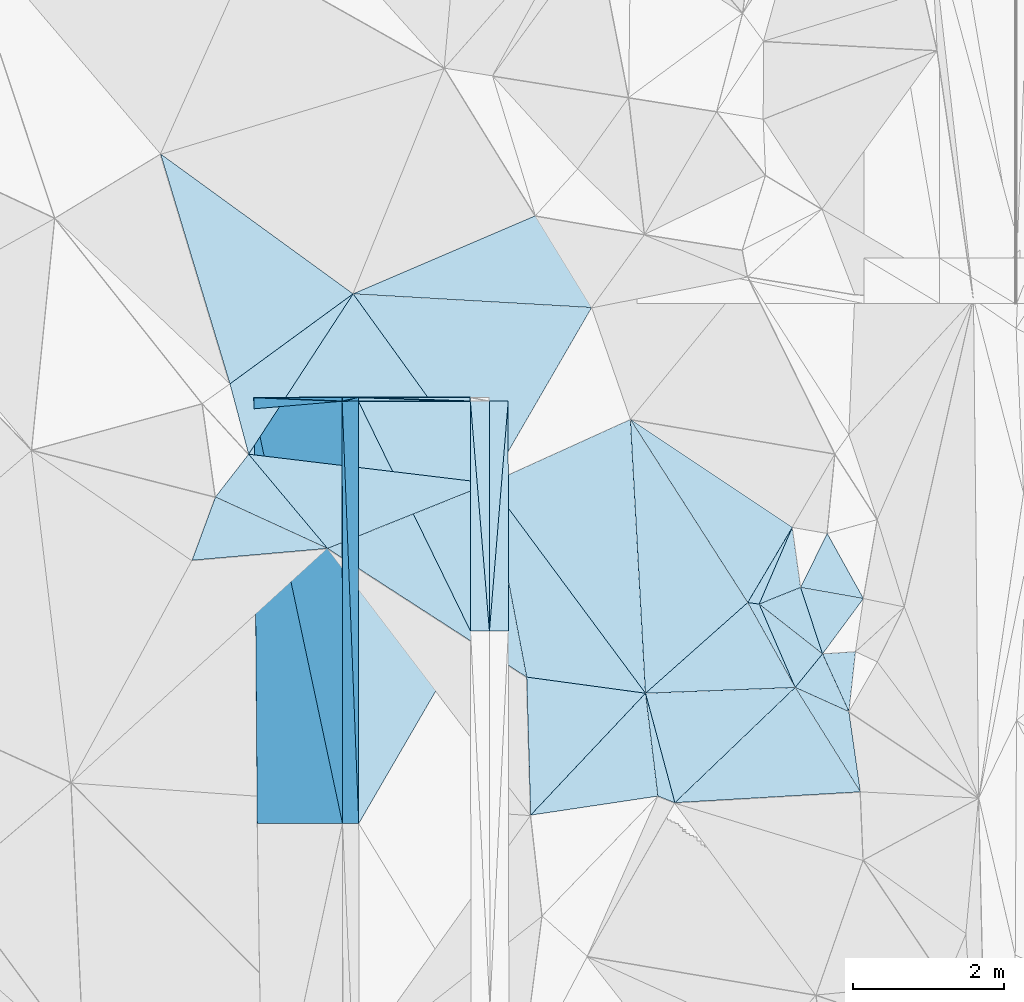
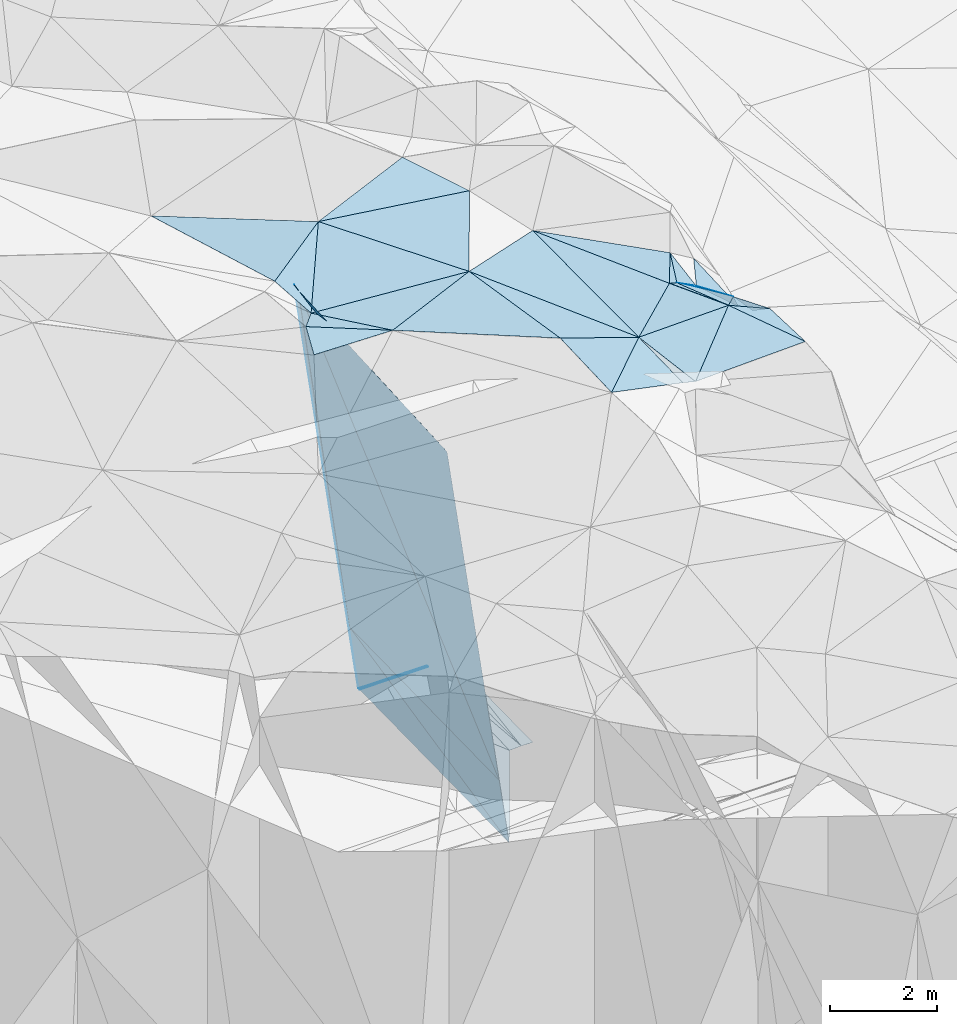
# One storey, part 80 of 275: 45 plates.
"""IFC2X3 building model written with IfcOpenShell, lengths in millimetres."""

from ifc_helpers import new_model, si_unit, frame, origin_with_axes, place, context, subcontext, project, spatial, polyline, outline, extrude, material, type_object, element, save


model = new_model("IFC2X3")

# Units and contexts
model_context = context("Model", 3, precision=1e-05, world=origin_with_axes())
body_context = subcontext(model_context, "Body", "Model", "MODEL_VIEW")
ifc_project = project(units=[si_unit("LENGTHUNIT", "METRE", prefix="MILLI"), si_unit("AREAUNIT", "SQUARE_METRE"), si_unit("VOLUMEUNIT", "CUBIC_METRE"), si_unit("MASSUNIT", "GRAM", prefix="KILO"), si_unit("TIMEUNIT", "SECOND"), si_unit("PLANEANGLEUNIT", "RADIAN"), si_unit("SOLIDANGLEUNIT", "STERADIAN"), si_unit("THERMODYNAMICTEMPERATUREUNIT", "DEGREE_CELSIUS"), si_unit("LUMINOUSINTENSITYUNIT", "LUMEN")], contexts=[model_context])

# Site, building, storey
site_placement = place(None, origin_with_axes())
site = spatial("IfcSite", under=ifc_project, at=site_placement, CompositionType="ELEMENT")
building_placement = place(site_placement, origin_with_axes())
building = spatial("IfcBuilding", under=site, at=building_placement, Name="Undefined", CompositionType="ELEMENT")
storey_placement = place(building_placement, origin_with_axes())
storey = spatial("IfcBuildingStorey", under=building, at=storey_placement, Name="Undefined", CompositionType="ELEMENT", Elevation=0.0)

# Plates
ifc_material = material()
plate_type_1 = type_object("IfcPlateType", PredefinedType="NOTDEFINED")
plate_1_placement = place(storey_placement, frame((-105791.284921922, 80749.9380813327, 44352.9042897814), z_axis=(-0.989947570044486, 0.00196890184857865, -0.141421115780237), x_axis=(0.141421311963071, 4.91399751710103e-05, -0.98994949876643)))
element("IfcPlate", 1, at=plate_1_placement, inside=storey, type_object=plate_type_1, material=ifc_material, Name="00_PR", context=body_context, shape_type="SweptSolid", body=[
    extrude(outline(polyline([(0.0, 0.0), (1515.22888183594, -4.05998434871435e-09), (1624.02136230469, 5581.98876953125), (0.0, 0.0)])), frame((-8.85201319254618e-08, 2.18876761149539e-07, -0.5000001331573), z_axis=(0.0, 0.0, 1.0), x_axis=(1.0, 0.0, 0.0)), (0.0, 0.0, 1.0), 1.0),
])
plate_2_placement = place(storey_placement, frame((-105572.453959058, 75168.0409271076, 42743.3752903089), z_axis=(-0.989947692939014, 0.00196865014119153, -0.141420259020221), x_axis=(-0.141421299045208, -0.000180723962738576, 0.989949485335093)))
element("IfcPlate", 2, at=plate_2_placement, inside=storey, type_object=plate_type_1, material=ifc_material, Name="00_PR", context=body_context, shape_type="SweptSolid", body=[
    extrude(outline(polyline([(0.0, 0.0), (1515.22875976563, -2.92493496090174e-09), (1623.29382324219, 5582.20068359375), (0.0, 0.0)])), frame((-8.85201319254618e-08, 2.18876761149539e-07, -0.5000001331573), z_axis=(0.0, 0.0, 1.0), x_axis=(1.0, 0.0, 0.0)), (0.0, 0.0, 1.0), 1.0),
])
plate_3_placement = place(storey_placement, frame((-99803.8316482704, 76967.5281254534, 51889.5093896797), z_axis=(-0.0232274915397897, 0.191756436899247, -0.981167647522315), x_axis=(0.521400404391622, -0.835060236363888, -0.175544922866318)))
element("IfcPlate", 3, at=plate_3_placement, inside=storey, type_object=plate_type_1, material=ifc_material, Name="00", context=body_context, shape_type="SweptSolid", body=[
    extrude(outline(polyline([(0.0, 0.0), (1651.99877929688, -3.17959347739816e-09), (488.378082275391, 2162.5185546875), (0.0, 0.0)])), frame((-8.85201319254618e-08, 2.18876761149539e-07, -0.5000001331573), z_axis=(0.0, 0.0, 1.0), x_axis=(1.0, 0.0, 0.0)), (0.0, 0.0, 1.0), 1.0),
])
plate_type_2 = type_object("IfcPlateType", PredefinedType="NOTDEFINED")
plate_4_placement = place(storey_placement, frame((-104096.478912705, 80750.5425580161, 42852.4757224716), z_axis=(0.0499210127241524, 0.0197592358296329, -0.998557692418432), x_axis=(0.998752271782221, 0.000352470097106165, 0.0499377149525702)))
element("IfcPlate", 4, at=plate_4_placement, inside=storey, type_object=plate_type_2, material=ifc_material, Name="00_PR", context=body_context, shape_type="SweptSolid", body=[
    extrude(outline(polyline([(0.0, 0.0), (250.311813354492, 5.0931703299284e-10), (248.073837280273, 3039.87841796875), (0.0, 0.0)])), frame((-8.85201319254618e-08, 2.18876761149539e-07, -0.5000001331573), z_axis=(0.0, 0.0, 1.0), x_axis=(1.0, 0.0, 0.0)), (0.0, 0.0, 1.0), 1.0),
])
plate_5_placement = place(storey_placement, frame((-103596.514485614, 80750.718089089, 42859.9751988708), z_axis=(-0.0199990045645929, 0.0197377331332107, -0.999605152901478), x_axis=(-0.0813661958591433, -0.99652083657103, -0.018048945985486)))
element("IfcPlate", 5, at=plate_5_placement, inside=storey, type_object=plate_type_2, material=ifc_material, Name="00_PR", context=body_context, shape_type="SweptSolid", body=[
    extrude(outline(polyline([(0.0, 0.0), (3049.98413085938, -2.15659383684397e-08), (20.3383045196533, 249.221405029297), (0.0, 0.0)])), frame((-8.85201319254618e-08, 2.18876761149539e-07, -0.5000001331573), z_axis=(0.0, 0.0, 1.0), x_axis=(1.0, 0.0, 0.0)), (0.0, 0.0, 1.0), 1.0),
])
plate_6_placement = place(storey_placement, frame((-103844.680107289, 77711.3452304612, 42804.9261990161), z_axis=(-0.0200090261599455, 0.0197385474792308, -0.999604936270095), x_axis=(0.0813661958601686, 0.99652083657088, 0.0180489459891191)))
element("IfcPlate", 6, at=plate_6_placement, inside=storey, type_object=plate_type_2, material=ifc_material, Name="00_PR", context=body_context, shape_type="SweptSolid", body=[
    extrude(outline(polyline([(0.0, 0.0), (3049.98413085938, -2.15659383684397e-08), (20.4645595550537, 249.210891723633), (0.0, 0.0)])), frame((-8.85201319254618e-08, 2.18876761149539e-07, -0.5000001331573), z_axis=(0.0, 0.0, 1.0), x_axis=(1.0, 0.0, 0.0)), (0.0, 0.0, 1.0), 1.0),
])
plate_type_3 = type_object("IfcPlateType", PredefinedType="NOTDEFINED")
plate_7_placement = place(storey_placement, frame((-99803.8231148454, 76967.4482879851, 51889.5002525735), z_axis=(-0.00629179550076333, 0.0321087437321873, -0.999464577604088), x_axis=(-0.99924356189352, -0.0385588471990684, 0.00505166477802372)))
element("IfcPlate", 7, at=plate_7_placement, inside=storey, type_object=plate_type_3, material=ifc_material, Name="00", context=body_context, shape_type="SweptSolid", body=[
    extrude(outline(polyline([(0.0, 0.0), (1979.54541015625, 9.85164660960436e-09), (583.770385742188, 1146.12915039063), (0.0, 0.0)])), frame((-8.85201319254618e-08, 2.18876761149539e-07, -0.5000001331573), z_axis=(0.0, 0.0, 1.0), x_axis=(1.0, 0.0, 0.0)), (0.0, 0.0, 1.0), 1.0),
])
plate_type_4 = type_object("IfcPlateType", PredefinedType="NOTDEFINED")
plate_8_placement = place(storey_placement, frame((-105791.284923544, 80749.9377926572, 44352.9042837932), z_axis=(-0.989947089847902, 0.00138709625020699, -0.141431380059949), x_axis=(-0.14143776096297, -0.0121480939673644, 0.989872609777007)))
element("IfcPlate", 8, at=plate_8_placement, inside=storey, type_object=plate_type_4, material=ifc_material, Name="00_PR", context=body_context, shape_type="SweptSolid", body=[
    extrude(outline(polyline([(0.0, 0.0), (8232.0, -2.18278728425503e-10), (8266.2177734375, 149.809234619141), (0.0, 0.0)])), frame((-8.85201319254618e-08, 2.18876761149539e-07, -0.5000001331573), z_axis=(0.0, 0.0, 1.0), x_axis=(1.0, 0.0, 0.0)), (0.0, 0.0, 1.0), 1.0),
])
plate_type_5 = type_object("IfcPlateType", PredefinedType="NOTDEFINED")
plate_9_placement = place(storey_placement, frame((-106955.600523948, 80649.9349784552, 52501.5352873033), z_axis=(-0.989947123095686, 0.00196872898852786, -0.141424246792215), x_axis=(0.141437760963285, 0.0121480939642409, -0.989872609777)))
element("IfcPlate", 9, at=plate_9_placement, inside=storey, type_object=plate_type_5, material=ifc_material, Name="00_PR", context=body_context, shape_type="SweptSolid", body=[
    extrude(outline(polyline([(0.0, 0.0), (8232.0, -2.18278728425503e-10), (8273.25, 5583.09423828125), (0.0, 0.0)])), frame((-8.85201319254618e-08, 2.18876761149539e-07, -0.5000001331573), z_axis=(0.0, 0.0, 1.0), x_axis=(1.0, 0.0, 0.0)), (0.0, 0.0, 1.0), 1.0),
])
plate_type_6 = type_object("IfcPlateType", PredefinedType="NOTDEFINED")
plate_10_placement = place(storey_placement, frame((-105786.738944398, 75167.7678460597, 44243.3752892735), z_axis=(-0.989947643888723, 0.00196324055124903, -0.14142067757476), x_axis=(-0.141421299045208, -0.000180723962738576, 0.989949485335093)))
element("IfcPlate", 10, at=plate_10_placement, inside=storey, type_object=plate_type_6, material=ifc_material, Name="00_PR", context=body_context, shape_type="SweptSolid", body=[
    extrude(outline(polyline([(0.0, 0.0), (7967.693359375, 1.04482751339674e-08), (8339.47265625, 5483.68505859375), (0.0, 0.0)])), frame((-8.85201319254618e-08, 2.18876761149539e-07, -0.5000001331573), z_axis=(0.0, 0.0, 1.0), x_axis=(1.0, 0.0, 0.0)), (0.0, 0.0, 1.0), 1.0),
])
plate_type_7 = type_object("IfcPlateType", PredefinedType="NOTDEFINED")
plate_11_placement = place(storey_placement, frame((-106960.492013354, 80799.316163194, 52537.2382896608), z_axis=(-0.989949441807876, -0.000335817680460565, -0.141421320495748), x_axis=(0.141421311963071, 4.91399751710103e-05, -0.98994949876643)))
element("IfcPlate", 11, at=plate_11_placement, inside=storey, type_object=plate_type_7, material=ifc_material, Name="00_PR", context=body_context, shape_type="SweptSolid", body=[
    extrude(outline(polyline([(0.0, 0.0), (8267.42578125, 1.72294676303864e-08), (8267.42578125, 49.7854995727539), (0.0, 0.0)])), frame((-8.85201319254618e-08, 2.18876761149539e-07, -0.5000001331573), z_axis=(0.0, 0.0, 1.0), x_axis=(1.0, 0.0, 0.0)), (0.0, 0.0, 1.0), 1.0),
])
plate_12_placement = place(storey_placement, frame((-105791.284922105, 80749.9369282165, 44352.9042896991), z_axis=(-0.989949415948489, -0.000337940094731569, -0.141421496455588), x_axis=(0.141334002059549, 0.0328874179853682, -0.989415543439705)))
element("IfcPlate", 12, at=plate_12_placement, inside=storey, type_object=plate_type_7, material=ifc_material, Name="00_PR", context=body_context, shape_type="SweptSolid", body=[
    extrude(outline(polyline([(0.0, 0.0), (1516.04650878906, -1.36788003146648e-09), (1514.41174316406, 49.7564125061035), (0.0, 0.0)])), frame((-8.85201319254618e-08, 2.18876761149539e-07, -0.5000001331573), z_axis=(0.0, 0.0, 1.0), x_axis=(1.0, 0.0, 0.0)), (0.0, 0.0, 1.0), 1.0),
])
plate_13_placement = place(storey_placement, frame((-104096.503873058, 80750.5326810639, 42852.4750005639), z_axis=(-2.50206221658913e-11, -2.85783213693808e-11, -1.0), x_axis=(-0.999446494019592, 0.0332671849116599, 2.40560528004289e-11)))
element("IfcPlate", 13, at=plate_13_placement, inside=storey, type_object=plate_type_7, material=ifc_material, Name="00_PR", context=body_context, shape_type="SweptSolid", body=[
    extrude(outline(polyline([(0.0, 0.0), (1480.83679199219, -5.58793544769287e-09), (1.67329227924347, 49.7439613342285), (0.0, 0.0)])), frame((-8.85201319254618e-08, 2.18876761149539e-07, -0.5000001331573), z_axis=(0.0, 0.0, 1.0), x_axis=(1.0, 0.0, 0.0)), (0.0, 0.0, 1.0), 1.0),
])
plate_14_placement = place(storey_placement, frame((-105576.504035367, 80750.0126897092, 42852.4750006009), z_axis=(-2.50206221658913e-11, -2.85783213693808e-11, -1.0), x_axis=(-0.000341371093283403, 0.999999941732887, -2.86459253608966e-11)))
element("IfcPlate", 14, at=plate_14_placement, inside=storey, type_object=plate_type_7, material=ifc_material, Name="00_PR", context=body_context, shape_type="SweptSolid", body=[
    extrude(outline(polyline([(0.0, 0.0), (49.7832641601563, 1.01863406598568e-10), (0.0147619508206844, 1480.00024414063), (0.0, 0.0)])), frame((-8.85201319254618e-08, 2.18876761149539e-07, -0.5000001331573), z_axis=(0.0, 0.0, 1.0), x_axis=(1.0, 0.0, 0.0)), (0.0, 0.0, 1.0), 1.0),
])
plate_15_placement = place(storey_placement, frame((-105577.016005805, 80799.7957822455, 42852.9042907308), z_axis=(-0.989949441807876, -0.000335817680460565, -0.141421320495748), x_axis=(-0.141334002020405, -0.0328874180215261, 0.989415543444095)))
element("IfcPlate", 15, at=plate_15_placement, inside=storey, type_object=plate_type_7, material=ifc_material, Name="00_PR", context=body_context, shape_type="SweptSolid", body=[
    extrude(outline(polyline([(0.0, 0.0), (1516.04650878906, -1.36788003146648e-09), (1514.41162109375, 49.7586479187012), (0.0, 0.0)])), frame((-8.85201319254618e-08, 2.18876761149539e-07, -0.5000001331573), z_axis=(0.0, 0.0, 1.0), x_axis=(1.0, 0.0, 0.0)), (0.0, 0.0, 1.0), 1.0),
])
plate_type_8 = type_object("IfcPlateType", PredefinedType="NOTDEFINED")
plate_16_placement = place(storey_placement, frame((-104094.669741401, 77711.1312088338, 42792.4260982054), z_axis=(-6.94003940892359e-06, 0.0197529271778155, -0.999804891876282), x_axis=(-0.438222690950985, 0.898691001671752, 0.0177582839795929)))
element("IfcPlate", 16, at=plate_16_placement, inside=storey, type_object=plate_type_8, material=ifc_material, Name="00_PR", context=body_context, shape_type="SweptSolid", body=[
    extrude(outline(polyline([(0.0, 0.0), (3381.46411132813, -1.18670868687332e-08), (2733.36181640625, 1330.55029296875), (0.0, 0.0)])), frame((-8.85201319254618e-08, 2.18876761149539e-07, -0.5000001331573), z_axis=(0.0, 0.0, 1.0), x_axis=(1.0, 0.0, 0.0)), (0.0, 0.0, 1.0), 1.0),
])
plate_type_9 = type_object("IfcPlateType", PredefinedType="NOTDEFINED")
plate_17_placement = place(storey_placement, frame((-105571.959131709, 75168.0497508533, 42742.9460971399), z_axis=(-0.000283939298451867, 0.0196179075839808, -0.999807510014053), x_axis=(-0.000814079102369363, 0.999807214483694, 0.019618132978729)))
element("IfcPlate", 17, at=plate_17_placement, inside=storey, type_object=plate_type_9, material=ifc_material, Name="00_PR", context=body_context, shape_type="SweptSolid", body=[
    extrude(outline(polyline([(0.0, 0.0), (5583.04931640625, -2.74012563750148e-08), (2542.35913085938, 1479.35949707031), (0.0, 0.0)])), frame((-8.85201319254618e-08, 2.18876761149539e-07, -0.5000001331573), z_axis=(0.0, 0.0, 1.0), x_axis=(1.0, 0.0, 0.0)), (0.0, 0.0, 1.0), 1.0),
])
plate_type_10 = type_object("IfcPlateType", PredefinedType="NOTDEFINED")
plate_18_placement = place(storey_placement, frame((-103844.645145139, 77711.3452385542, 42804.9267221315), z_axis=(0.0499110671627415, 0.01975841961421, -0.998558205729153), x_axis=(-0.998751970163721, -0.000855051096059, -0.0499376709680105)))
element("IfcPlate", 18, at=plate_18_placement, inside=storey, type_object=plate_type_10, material=ifc_material, Name="00_PR", context=body_context, shape_type="SweptSolid", body=[
    extrude(outline(polyline([(0.0, 0.0), (250.312026977539, 1.89174897968769e-10), (246.546325683594, 3040.00268554688), (0.0, 0.0)])), frame((-8.85201319254618e-08, 2.18876761149539e-07, -0.5000001331573), z_axis=(0.0, 0.0, 1.0), x_axis=(1.0, 0.0, 0.0)), (0.0, 0.0, 1.0), 1.0),
])
plate_type_11 = type_object("IfcPlateType", PredefinedType="NOTDEFINED")
plate_19_placement = place(storey_placement, frame((-105646.055142245, 82169.4247840882, 52689.5042875049), z_axis=(0.036907014479113, 0.125639887972514, -0.991389172238881), x_axis=(0.583262354044024, -0.808263273619389, -0.0807186897384545)))
element("IfcPlate", 19, at=plate_19_placement, inside=storey, type_object=plate_type_11, material=ifc_material, Name="00", context=body_context, shape_type="SweptSolid", body=[
    extrude(outline(polyline([(0.0, 0.0), (3097.17602539063, -4.24188328906894e-09), (933.366333007813, 2372.76782226563), (0.0, 0.0)])), frame((-8.85201319254618e-08, 2.18876761149539e-07, -0.5000001331573), z_axis=(0.0, 0.0, 1.0), x_axis=(1.0, 0.0, 0.0)), (0.0, 0.0, 1.0), 1.0),
])
plate_type_12 = type_object("IfcPlateType", PredefinedType="NOTDEFINED")
plate_20_placement = place(storey_placement, frame((-99803.9221546231, 76967.3925074128, 51889.5121499007), z_axis=(-0.204349669497472, -0.0794567202062592, -0.975667895438985), x_axis=(-0.487712394502274, 0.872450286408261, 0.0310985207847765)))
element("IfcPlate", 20, at=plate_20_placement, inside=storey, type_object=plate_type_12, material=ifc_material, Name="00", context=body_context, shape_type="SweptSolid", body=[
    extrude(outline(polyline([(0.0, 0.0), (1286.23486328125, -2.00816430151463e-09), (1193.56127929688, 124.946411132813), (0.0, 0.0)])), frame((-8.85201319254618e-08, 2.18876761149539e-07, -0.5000001331573), z_axis=(0.0, 0.0, 1.0), x_axis=(1.0, 0.0, 0.0)), (0.0, 0.0, 1.0), 1.0),
])
plate_type_13 = type_object("IfcPlateType", PredefinedType="NOTDEFINED")
plate_21_placement = place(storey_placement, frame((-105984.79793379, 78805.0789798718, 52369.517463274), z_axis=(-0.200959034140363, -0.168271223022941, -0.965038995118713), x_axis=(-0.902876290154087, 0.414003404439092, 0.115825669825106)))
element("IfcPlate", 21, at=plate_21_placement, inside=storey, type_object=plate_type_13, material=ifc_material, Name="00", context=body_context, shape_type="SweptSolid", body=[
    extrude(outline(polyline([(0.0, 0.0), (1640.39624023438, -9.76797309704125e-09), (1456.47729492188, 717.477416992188), (0.0, 0.0)])), frame((-8.85201319254618e-08, 2.18876761149539e-07, -0.5000001331573), z_axis=(0.0, 0.0, 1.0), x_axis=(1.0, 0.0, 0.0)), (0.0, 0.0, 1.0), 1.0),
])
plate_type_14 = type_object("IfcPlateType", PredefinedType="NOTDEFINED")
plate_22_placement = place(storey_placement, frame((-101781.893495417, 76891.1444704102, 51899.5023409329), z_axis=(-0.0510561112731081, 0.0824542954493876, -0.995286171241022), x_axis=(-0.0550004022374616, 0.994841341232808, 0.0852388498738943)))
element("IfcPlate", 22, at=plate_22_placement, inside=storey, type_object=plate_type_14, material=ifc_material, Name="00", context=body_context, shape_type="SweptSolid", body=[
    extrude(outline(polyline([(0.0, 0.0), (3636.83935546875, 3.81260178983212e-09), (1120.58837890625, 1416.36206054688), (0.0, 0.0)])), frame((-8.85201319254618e-08, 2.18876761149539e-07, -0.5000001331573), z_axis=(0.0, 0.0, 1.0), x_axis=(1.0, 0.0, 0.0)), (0.0, 0.0, 1.0), 1.0),
])
plate_type_15 = type_object("IfcPlateType", PredefinedType="NOTDEFINED")
plate_23_placement = place(storey_placement, frame((-101781.986398935, 76891.1396481497, 51899.5155920818), z_axis=(-0.236883190197546, 0.0728567279419433, -0.968802483169519), x_axis=(-0.681376365106877, -0.72328060636841, 0.112211467885798)))
element("IfcPlate", 23, at=plate_23_placement, inside=storey, type_object=plate_type_15, material=ifc_material, Name="00", context=body_context, shape_type="SweptSolid", body=[
    extrude(outline(polyline([(0.0, 0.0), (2227.93627929688, 2.91038304567337e-09), (960.619934082031, 1322.34997558594), (0.0, 0.0)])), frame((-8.85201319254618e-08, 2.18876761149539e-07, -0.5000001331573), z_axis=(0.0, 0.0, 1.0), x_axis=(1.0, 0.0, 0.0)), (0.0, 0.0, 1.0), 1.0),
])
plate_type_16 = type_object("IfcPlateType", PredefinedType="NOTDEFINED")
plate_24_placement = place(storey_placement, frame((-101781.828638942, 76891.2048428535, 51899.5120107366), z_axis=(0.0786314359179198, 0.203249848842396, -0.975964444142833), x_axis=(0.254988611242597, -0.950529769162027, -0.177409036053283)))
element("IfcPlate", 24, at=plate_24_placement, inside=storey, type_object=plate_type_16, material=ifc_material, Name="00", context=body_context, shape_type="SweptSolid", body=[
    extrude(outline(polyline([(0.0, 0.0), (1521.90673828125, -3.60887497663498e-09), (1382.27917480469, 195.714508056641), (0.0, 0.0)])), frame((-8.85201319254618e-08, 2.18876761149539e-07, -0.5000001331573), z_axis=(0.0, 0.0, 1.0), x_axis=(1.0, 0.0, 0.0)), (0.0, 0.0, 1.0), 1.0),
])
plate_type_17 = type_object("IfcPlateType", PredefinedType="NOTDEFINED")
plate_25_placement = place(storey_placement, frame((-103300.087224531, 75279.7544568081, 52149.5308556074), z_axis=(-0.312321860944385, 0.148661284741843, -0.938272283292617), x_axis=(0.6813763651129, 0.723280606362734, -0.112211467885814)))
element("IfcPlate", 25, at=plate_25_placement, inside=storey, type_object=plate_type_17, material=ifc_material, Name="00", context=body_context, shape_type="SweptSolid", body=[
    extrude(outline(polyline([(0.0, 0.0), (2227.93627929688, 2.91038304567337e-09), (1386.30541992188, 1113.84802246094), (0.0, 0.0)])), frame((-8.85201319254618e-08, 2.18876761149539e-07, -0.5000001331573), z_axis=(0.0, 0.0, 1.0), x_axis=(1.0, 0.0, 0.0)), (0.0, 0.0, 1.0), 1.0),
])
plate_type_18 = type_object("IfcPlateType", PredefinedType="NOTDEFINED")
plate_26_placement = place(storey_placement, frame((-105984.692374442, 78805.191306216, 52369.5008136212), z_axis=(0.00992438602888727, 0.0564504512416539, -0.998356075314095), x_axis=(0.927628723286289, 0.372274923308242, 0.0302709961859764)))
element("IfcPlate", 26, at=plate_26_placement, inside=storey, type_object=plate_type_18, material=ifc_material, Name="00", context=body_context, shape_type="SweptSolid", body=[
    extrude(outline(polyline([(0.0, 0.0), (2312.44458007813, 9.41508915275335e-09), (1806.70275878906, 2561.93774414063), (0.0, 0.0)])), frame((-8.85201319254618e-08, 2.18876761149539e-07, -0.5000001331573), z_axis=(0.0, 0.0, 1.0), x_axis=(1.0, 0.0, 0.0)), (0.0, 0.0, 1.0), 1.0),
])
plate_type_19 = type_object("IfcPlateType", PredefinedType="NOTDEFINED")
plate_27_placement = place(storey_placement, frame((-107465.819764796, 79484.328086267, 52559.5034984947), z_axis=(-0.0949849985330019, 0.070655203283821, -0.992968122500721), x_axis=(0.902876290006994, -0.414003404787041, -0.115825669728018)))
element("IfcPlate", 27, at=plate_27_placement, inside=storey, type_object=plate_type_19, material=ifc_material, Name="00", context=body_context, shape_type="SweptSolid", body=[
    extrude(outline(polyline([(0.0, 0.0), (1640.39624023438, -9.76797309704125e-09), (71.2632675170898, 888.719055175781), (0.0, 0.0)])), frame((-8.85201319254618e-08, 2.18876761149539e-07, -0.5000001331573), z_axis=(0.0, 0.0, 1.0), x_axis=(1.0, 0.0, 0.0)), (0.0, 0.0, 1.0), 1.0),
])
plate_type_20 = type_object("IfcPlateType", PredefinedType="NOTDEFINED")
plate_28_placement = place(storey_placement, frame((-99442.6326273118, 77411.3415252386, 51689.5293017915), z_axis=(-0.265950957055247, -0.207605839664853, -0.941365977597687), x_axis=(0.41376834806707, -0.906587101694012, 0.0830396361980191)))
element("IfcPlate", 28, at=plate_28_placement, inside=storey, type_object=plate_type_20, material=ifc_material, Name="00", context=body_context, shape_type="SweptSolid", body=[
    extrude(outline(polyline([(0.0, 0.0), (842.970947265625, 4.14729584008455e-09), (269.641571044922, 543.132995605469), (0.0, 0.0)])), frame((-8.85201319254618e-08, 2.18876761149539e-07, -0.5000001331573), z_axis=(0.0, 0.0, 1.0), x_axis=(1.0, 0.0, 0.0)), (0.0, 0.0, 1.0), 1.0),
])
plate_type_21 = type_object("IfcPlateType", PredefinedType="NOTDEFINED")
plate_29_placement = place(storey_placement, frame((-101393.805123642, 75444.5758173892, 51629.5082092825), z_axis=(-0.0119322102476395, 0.180366793619277, -0.983527041884516), x_axis=(-0.254988611715858, 0.950529769039987, 0.177409036026942)))
element("IfcPlate", 29, at=plate_29_placement, inside=storey, type_object=plate_type_21, material=ifc_material, Name="00", context=body_context, shape_type="SweptSolid", body=[
    extrude(outline(polyline([(0.0, 0.0), (1521.90673828125, -3.60887497663498e-09), (1088.30590820313, 1931.4736328125), (0.0, 0.0)])), frame((-8.85201319254618e-08, 2.18876761149539e-07, -0.5000001331573), z_axis=(0.0, 0.0, 1.0), x_axis=(1.0, 0.0, 0.0)), (0.0, 0.0, 1.0), 1.0),
])
plate_type_22 = type_object("IfcPlateType", PredefinedType="NOTDEFINED")
plate_30_placement = place(storey_placement, frame((-103839.730419086, 79666.0313280859, 52439.5153540147), z_axis=(-0.246052561959251, 0.00615364804697197, -0.969236952127292), x_axis=(0.588499899538112, -0.793610265592347, -0.154436441910827)))
element("IfcPlate", 30, at=plate_30_placement, inside=storey, type_object=plate_type_22, material=ifc_material, Name="00", context=body_context, shape_type="SweptSolid", body=[
    extrude(outline(polyline([(0.0, 0.0), (3496.583984375, 8.29459168016911e-09), (2341.42797851563, 1156.29345703125), (0.0, 0.0)])), frame((-8.85201319254618e-08, 2.18876761149539e-07, -0.5000001331573), z_axis=(0.0, 0.0, 1.0), x_axis=(1.0, 0.0, 0.0)), (0.0, 0.0, 1.0), 1.0),
])
plate_type_23 = type_object("IfcPlateType", PredefinedType="NOTDEFINED")
plate_31_placement = place(storey_placement, frame((-105646.113328639, 82169.4546946005, 52689.5102653815), z_axis=(-0.0794654527077797, 0.185460694595191, -0.979433291544767), x_axis=(0.919176792794131, 0.393845177180953, 1.68541230715873e-10)))
element("IfcPlate", 31, at=plate_31_placement, inside=storey, type_object=plate_type_23, material=ifc_material, Name="00", context=body_context, shape_type="SweptSolid", body=[
    extrude(outline(polyline([(0.0, 0.0), (2620.17163085938, -7.27595761418343e-11), (2826.30322265625, 1437.29248046875), (0.0, 0.0)])), frame((-8.85201319254618e-08, 2.18876761149539e-07, -0.5000001331573), z_axis=(0.0, 0.0, 1.0), x_axis=(1.0, 0.0, 0.0)), (0.0, 0.0, 1.0), 1.0),
])
plate_type_24 = type_object("IfcPlateType", PredefinedType="NOTDEFINED")
plate_32_placement = place(storey_placement, frame((-99842.6274686952, 79082.5846534647, 51819.6269396002), z_axis=(-0.630715688635991, 0.213422153722774, -0.746088938672033), x_axis=(0.127705813250771, -0.919783287831721, -0.371065935768064)))
element("IfcPlate", 32, at=plate_32_placement, inside=storey, type_object=plate_type_24, material=ifc_material, Name="00", context=body_context, shape_type="SweptSolid", body=[
    extrude(outline(polyline([(0.0, 0.0), (862.380432128906, -2.459273673594e-09), (846.610107421875, 712.91748046875), (0.0, 0.0)])), frame((-8.85201319254618e-08, 2.18876761149539e-07, -0.5000001331573), z_axis=(0.0, 0.0, 1.0), x_axis=(1.0, 0.0, 0.0)), (0.0, 0.0, 1.0), 1.0),
])
plate_type_25 = type_object("IfcPlateType", PredefinedType="NOTDEFINED")
plate_33_placement = place(storey_placement, frame((-100280.119177906, 78068.8385929841, 51899.5897631832), z_axis=(-0.465931905492044, -0.331335123319931, -0.82044164661426), x_axis=(0.76807088600507, 0.308895096066217, -0.56093754883911)))
element("IfcPlate", 33, at=plate_33_placement, inside=storey, type_object=plate_type_25, material=ifc_material, Name="00", context=body_context, shape_type="SweptSolid", body=[
    extrude(outline(polyline([(0.0, 0.0), (713.091857910156, -3.84170562028885e-09), (557.852416992188, 930.860168457031), (0.0, 0.0)])), frame((-8.85201319254618e-08, 2.18876761149539e-07, -0.5000001331573), z_axis=(0.0, 0.0, 1.0), x_axis=(1.0, 0.0, 0.0)), (0.0, 0.0, 1.0), 1.0),
])
plate_type_26 = type_object("IfcPlateType", PredefinedType="NOTDEFINED")
plate_34_placement = place(storey_placement, frame((-100280.057534123, 78068.9344391235, 51899.5354682835), z_axis=(-0.342638492744633, -0.139644352417682, -0.929030848856771), x_axis=(0.771629190974828, -0.605922868713142, -0.193509350693887)))
element("IfcPlate", 34, at=plate_34_placement, inside=storey, type_object=plate_type_26, material=ifc_material, Name="00", context=body_context, shape_type="SweptSolid", body=[
    extrude(outline(polyline([(0.0, 0.0), (1085.21887207031, 3.84170562028885e-09), (1036.74938964844, 604.442504882813), (0.0, 0.0)])), frame((-8.85201319254618e-08, 2.18876761149539e-07, -0.5000001331573), z_axis=(0.0, 0.0, 1.0), x_axis=(1.0, 0.0, 0.0)), (0.0, 0.0, 1.0), 1.0),
])
plate_type_27 = type_object("IfcPlateType", PredefinedType="NOTDEFINED")
plate_35_placement = place(storey_placement, frame((-107027.108803239, 80050.1090773876, 52369.5169880988), z_axis=(-0.124232260357597, 0.22680205143537, -0.965985080087239), x_axis=(-0.248493309599873, 0.935392931168826, 0.251577303037246)))
element("IfcPlate", 35, at=plate_35_placement, inside=storey, type_object=plate_type_27, material=ifc_material, Name="00", context=body_context, shape_type="SweptSolid", body=[
    extrude(outline(polyline([(0.0, 0.0), (993.730346679688, -1.41153577715158e-09), (1719.78247070313, 1882.43151855469), (0.0, 0.0)])), frame((-8.85201319254618e-08, 2.18876761149539e-07, -0.5000001331573), z_axis=(0.0, 0.0, 1.0), x_axis=(1.0, 0.0, 0.0)), (0.0, 0.0, 1.0), 1.0),
])
plate_type_28 = type_object("IfcPlateType", PredefinedType="NOTDEFINED")
plate_36_placement = place(storey_placement, frame((-103839.595191948, 79666.0384685035, 52439.5002270524), z_axis=(0.0244125175921135, 0.0204415997567667, -0.999492956445516), x_axis=(-0.927628723116358, -0.372274923728429, -0.0302709962258894)))
element("IfcPlate", 36, at=plate_36_placement, inside=storey, type_object=plate_type_28, material=ifc_material, Name="00", context=body_context, shape_type="SweptSolid", body=[
    extrude(outline(polyline([(0.0, 0.0), (2312.44458007813, 9.41508915275335e-09), (2815.93774414063, 1543.56555175781), (0.0, 0.0)])), frame((-8.85201319254618e-08, 2.18876761149539e-07, -0.5000001331573), z_axis=(0.0, 0.0, 1.0), x_axis=(1.0, 0.0, 0.0)), (0.0, 0.0, 1.0), 1.0),
])
plate_type_29 = type_object("IfcPlateType", PredefinedType="NOTDEFINED")
plate_37_placement = place(storey_placement, frame((-100431.222903337, 78089.6072186745, 51929.5082018194), z_axis=(-0.180546865675965, -0.00189592027336961, -0.983564555472035), x_axis=(-0.537062578301547, 0.837950238066034, 0.0969700237865923)))
element("IfcPlate", 37, at=plate_37_placement, inside=storey, type_object=plate_type_29, material=ifc_material, Name="00", context=body_context, shape_type="SweptSolid", body=[
    extrude(outline(polyline([(0.0, 0.0), (2887.490234375, -1.06447259895504e-08), (505.075286865234, 1043.79064941406), (0.0, 0.0)])), frame((-8.85201319254618e-08, 2.18876761149539e-07, -0.5000001331573), z_axis=(0.0, 0.0, 1.0), x_axis=(1.0, 0.0, 0.0)), (0.0, 0.0, 1.0), 1.0),
])
plate_type_30 = type_object("IfcPlateType", PredefinedType="NOTDEFINED")
plate_38_placement = place(storey_placement, frame((-99732.4552099109, 78289.4524886459, 51499.6214079865), z_axis=(-0.548167785375059, 0.355294229292049, -0.757151299086762), x_axis=(0.440100540610461, 0.892350598792733, 0.100109554931734)))
element("IfcPlate", 38, at=plate_38_placement, inside=storey, type_object=plate_type_30, material=ifc_material, Name="00", context=body_context, shape_type="SweptSolid", body=[
    extrude(outline(polyline([(0.0, 0.0), (799.12451171875, 4.77302819490433e-09), (167.308090209961, 1063.86462402344), (0.0, 0.0)])), frame((-8.85201319254618e-08, 2.18876761149539e-07, -0.5000001331573), z_axis=(0.0, 0.0, 1.0), x_axis=(1.0, 0.0, 0.0)), (0.0, 0.0, 1.0), 1.0),
])
plate_type_31 = type_object("IfcPlateType", PredefinedType="NOTDEFINED")
plate_39_placement = place(storey_placement, frame((-101781.946128701, 76891.1411145246, 51899.5075835088), z_axis=(-0.15630118890559, 0.0757374136248737, -0.984801392425962), x_axis=(-0.588499899199825, 0.793610265874008, 0.154436441752525)))
element("IfcPlate", 39, at=plate_39_placement, inside=storey, type_object=plate_type_31, material=ifc_material, Name="00", context=body_context, shape_type="SweptSolid", body=[
    extrude(outline(polyline([(0.0, 0.0), (3496.583984375, 8.29459168016911e-09), (3036.935546875, 2000.90563964844), (0.0, 0.0)])), frame((-8.85201319254618e-08, 2.18876761149539e-07, -0.5000001331573), z_axis=(0.0, 0.0, 1.0), x_axis=(1.0, 0.0, 0.0)), (0.0, 0.0, 1.0), 1.0),
])
plate_type_32 = type_object("IfcPlateType", PredefinedType="NOTDEFINED")
plate_40_placement = place(storey_placement, frame((-99842.4089931235, 79082.4810507939, 51819.5094679796), z_axis=(-0.19374349051389, 0.00621084639021974, -0.981032560759637), x_axis=(-0.395351659913391, -0.915681481321308, 0.0722806320458094)))
element("IfcPlate", 40, at=plate_40_placement, inside=storey, type_object=plate_type_32, material=ifc_material, Name="00", context=body_context, shape_type="SweptSolid", body=[
    extrude(outline(polyline([(0.0, 0.0), (1106.79724121094, 4.17639967054129e-09), (1149.89453125, 149.474487304688), (0.0, 0.0)])), frame((-8.85201319254618e-08, 2.18876761149539e-07, -0.5000001331573), z_axis=(0.0, 0.0, 1.0), x_axis=(1.0, 0.0, 0.0)), (0.0, 0.0, 1.0), 1.0),
])
plate_type_33 = type_object("IfcPlateType", PredefinedType="NOTDEFINED")
plate_41_placement = place(storey_placement, frame((-105646.053033054, 82169.3632344669, 52689.5004064134), z_axis=(0.0411066672466028, 0.00254044647604227, -0.999151534072575), x_axis=(-0.806854832390431, -0.589730069855184, -0.0346947280838071)))
element("IfcPlate", 41, at=plate_41_placement, inside=storey, type_object=plate_type_33, material=ifc_material, Name="00", context=body_context, shape_type="SweptSolid", body=[
    extrude(outline(polyline([(0.0, 0.0), (2017.59753417969, 1.59197952598333e-08), (966.496032714844, 2995.1103515625), (0.0, 0.0)])), frame((-8.85201319254618e-08, 2.18876761149539e-07, -0.5000001331573), z_axis=(0.0, 0.0, 1.0), x_axis=(1.0, 0.0, 0.0)), (0.0, 0.0, 1.0), 1.0),
])
plate_type_34 = type_object("IfcPlateType", PredefinedType="NOTDEFINED")
plate_42_placement = place(storey_placement, frame((-102493.817487463, 81988.5505404819, 52399.5022962092), z_axis=(-0.0895764137855327, 0.0347642406543212, -0.995373052510993), x_axis=(-0.501322802732142, -0.865132035008249, 0.0148999819891188)))
element("IfcPlate", 42, at=plate_42_placement, inside=storey, type_object=plate_type_34, material=ifc_material, Name="00", context=body_context, shape_type="SweptSolid", body=[
    extrude(outline(polyline([(0.0, 0.0), (2684.56689453125, 2.12457962334156e-09), (1428.20056152344, 2830.90844726563), (0.0, 0.0)])), frame((-8.85201319254618e-08, 2.18876761149539e-07, -0.5000001331573), z_axis=(0.0, 0.0, 1.0), x_axis=(1.0, 0.0, 0.0)), (0.0, 0.0, 1.0), 1.0),
])
plate_type_35 = type_object("IfcPlateType", PredefinedType="NOTDEFINED")
plate_43_placement = place(storey_placement, frame((-99094.0468289659, 76647.0339415661, 51759.6853087468), z_axis=(-0.683600144334859, -0.369640667476249, -0.629330294529886), x_axis=(-0.413768348476484, 0.906587101523647, -0.0830396360179617)))
element("IfcPlate", 43, at=plate_43_placement, inside=storey, type_object=plate_type_35, material=ifc_material, Name="00", context=body_context, shape_type="SweptSolid", body=[
    extrude(outline(polyline([(0.0, 0.0), (842.970947265625, 4.14729584008455e-09), (729.325256347656, 646.362609863281), (0.0, 0.0)])), frame((-8.85201319254618e-08, 2.18876761149539e-07, -0.5000001331573), z_axis=(0.0, 0.0, 1.0), x_axis=(1.0, 0.0, 0.0)), (0.0, 0.0, 1.0), 1.0),
])
plate_type_36 = type_object("IfcPlateType", PredefinedType="NOTDEFINED")
plate_44_placement = place(storey_placement, frame((-99803.8804859935, 76967.4979214484, 51889.508006324), z_axis=(-0.120895634293436, 0.131355704056949, -0.983935935221644), x_axis=(0.899167952617409, -0.40546347855538, -0.164609721898762)))
element("IfcPlate", 44, at=plate_44_placement, inside=storey, type_object=plate_type_36, material=ifc_material, Name="00", context=body_context, shape_type="SweptSolid", body=[
    extrude(outline(polyline([(0.0, 0.0), (789.746765136719, 8.33097146824002e-10), (1381.58203125, 905.721252441406), (0.0, 0.0)])), frame((-8.85201319254618e-08, 2.18876761149539e-07, -0.5000001331573), z_axis=(0.0, 0.0, 1.0), x_axis=(1.0, 0.0, 0.0)), (0.0, 0.0, 1.0), 1.0),
])
plate_type_37 = type_object("IfcPlateType", PredefinedType="NOTDEFINED")
plate_45_placement = place(storey_placement, frame((-99442.8117784145, 77411.2671153124, 51689.6523287856), z_axis=(-0.624112813825559, -0.356446377805245, -0.695290712844824), x_axis=(-0.306958286496477, 0.930183927629766, -0.201331743971014)))
element("IfcPlate", 45, at=plate_45_placement, inside=storey, type_object=plate_type_37, material=ifc_material, Name="00", context=body_context, shape_type="SweptSolid", body=[
    extrude(outline(polyline([(0.0, 0.0), (943.716064453125, 2.99769453704357e-09), (687.177001953125, 1045.93872070313), (0.0, 0.0)])), frame((-8.85201319254618e-08, 2.18876761149539e-07, -0.5000001331573), z_axis=(0.0, 0.0, 1.0), x_axis=(1.0, 0.0, 0.0)), (0.0, 0.0, 1.0), 1.0),
])

save(model, "model.ifc")
